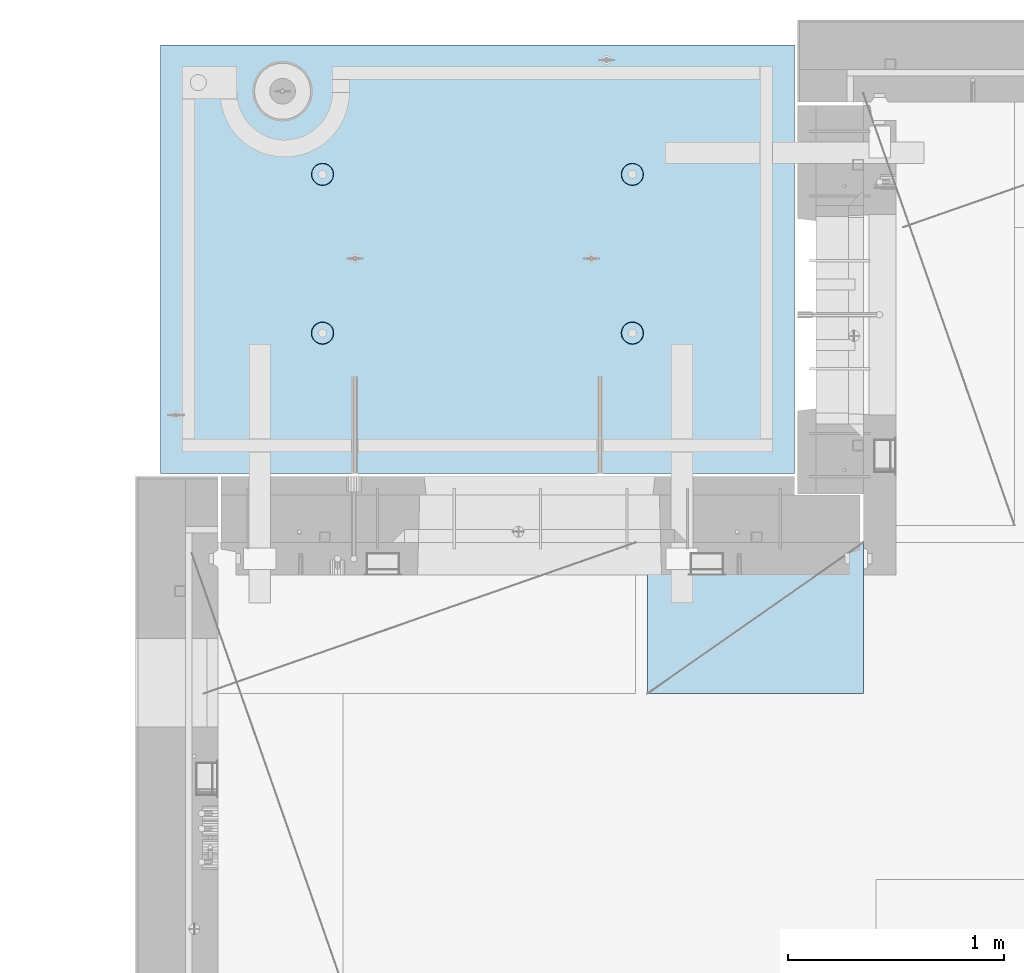
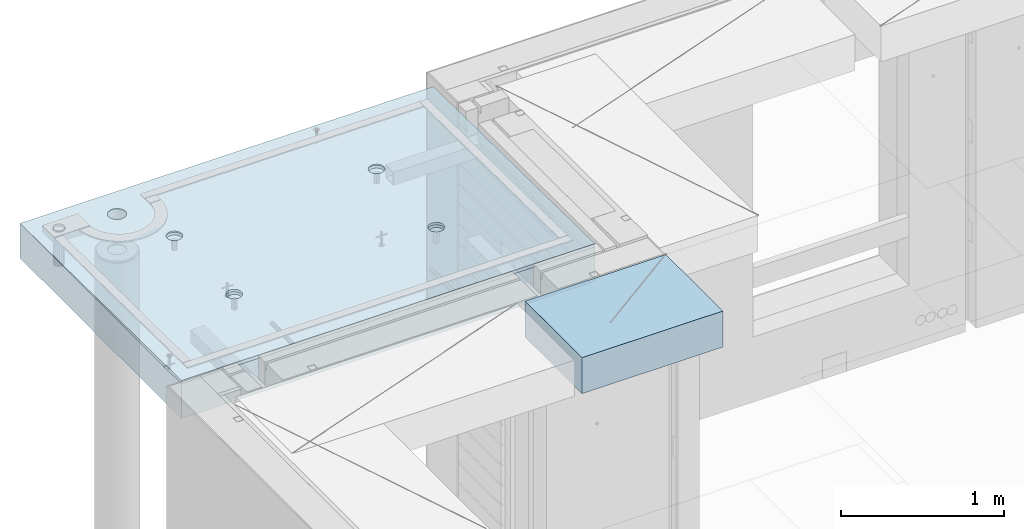
# One storey, part 199 of 341: 2 slabs, 1 plate, 2 elements without a shape of their own.
"""IFC2X3 building model written with IfcOpenShell, lengths in millimetres."""

import ifcopenshell
import ifcopenshell.guid

model = None  # the IFC model being written
_history = None  # IfcOwnerHistory: only IFC2X3 demands one
_inside = {}  # id of a spatial element -> (the spatial element, [elements in it])
_under = {}  # id of a project, library or spatial element -> (it, [spatial elements below it])
_declared = {}  # id of a project -> (the project, [libraries it declares])
_typed = {}  # id of a type object -> (the type object, [elements of that type])
_made_of = {}  # id of a material, layer set ... -> (it, [elements and type objects made of it])


def new_model(schema):
    """Start an empty IFC model of exactly this schema.

    Asked for "IFC4X3", IfcOpenShell would pick the latest addendum, in which some entities
    have other attributes; the version numbers below select the first issue.
    IFC2X3 requires an IfcOwnerHistory on every rooted entity: one is made here for all.
    """
    global model, _history
    if schema == "IFC4X3":
        model = ifcopenshell.file(schema_version=(4, 3, 0, 0))
    else:
        model = ifcopenshell.file(schema=schema)
    _inside.clear()
    _under.clear()
    _declared.clear()
    _typed.clear()
    _made_of.clear()
    _history = None
    if model.schema == "IFC2X3":
        org = make("IfcOrganization", Name="unknown")
        user = make(
            "IfcPersonAndOrganization",
            ThePerson=make("IfcPerson", FamilyName="unknown"),
            TheOrganization=org,
        )
        app = make(
            "IfcApplication",
            ApplicationDeveloper=org,
            Version="unknown",
            ApplicationFullName="unknown",
            ApplicationIdentifier="unknown",
        )
        _history = make(
            "IfcOwnerHistory",
            OwningUser=user,
            OwningApplication=app,
            ChangeAction="ADDED",
            CreationDate=0,
        )
    return model


def make(cls, **values):
    """One entity of the class cls with the attributes given. An attribute that is None is left unset."""
    return model.create_entity(
        cls, **{name: value for name, value in values.items() if value is not None}
    )


def rooted(cls, **values):
    """An entity with a GlobalId (a new one), such as an element, a storey or a relation."""
    return make(cls, GlobalId=ifcopenshell.guid.new(), OwnerHistory=_history, **values)


def si_unit(unit_type, name, prefix=None):
    """IfcSIUnit, for example si_unit("LENGTHUNIT", "METRE", prefix="MILLI")."""
    return make("IfcSIUnit", UnitType=unit_type, Prefix=prefix, Name=name)


def assignment(units):
    """IfcUnitAssignment: the units of a project."""
    return None if units is None else make("IfcUnitAssignment", Units=units)


def point(xyz):
    """IfcCartesianPoint."""
    return None if xyz is None else make("IfcCartesianPoint", Coordinates=xyz)


def direction(xyz):
    """IfcDirection."""
    return None if xyz is None else make("IfcDirection", DirectionRatios=xyz)


def frame(location, z_axis=None, x_axis=None):
    """IfcAxis2Placement3D, a coordinate frame: its origin and axes. An axis left out is left unset."""
    return make(
        "IfcAxis2Placement3D",
        Location=point(location),
        Axis=direction(z_axis),
        RefDirection=direction(x_axis),
    )


def origin_with_axes():
    """The frame at (0, 0, 0) with the z axis (0, 0, 1) and the x axis (1, 0, 0) written out."""
    return frame((0.0, 0.0, 0.0), z_axis=(0.0, 0.0, 1.0), x_axis=(1.0, 0.0, 0.0))


def place(relative_to, where):
    """IfcLocalPlacement: puts the frame where relative to a parent placement (None: the world)."""
    return make(
        "IfcLocalPlacement", PlacementRelTo=relative_to, RelativePlacement=where
    )


def context(
    kind, dimensions, precision=None, world=None, true_north=None, identifier=None
):
    """IfcGeometricRepresentationContext, for example the 3D "Model" context."""
    return make(
        "IfcGeometricRepresentationContext",
        ContextIdentifier=identifier,
        ContextType=kind,
        CoordinateSpaceDimension=dimensions,
        Precision=precision,
        WorldCoordinateSystem=world,
        TrueNorth=true_north,
    )


def subcontext(parent, identifier, kind, view, scale=None):
    """IfcGeometricRepresentationSubContext, for example "Body" below "Model"."""
    return make(
        "IfcGeometricRepresentationSubContext",
        ContextIdentifier=identifier,
        ContextType=kind,
        ParentContext=parent,
        TargetScale=scale,
        TargetView=view,
    )


def project(units=None, contexts=None):
    """IfcProject with its units and contexts."""
    return rooted(
        "IfcProject",
        Name="project",
        RepresentationContexts=contexts,
        UnitsInContext=assignment(units),
    )


def spatial(cls, under=None, at=None, **own):
    """A site, building, storey or space (cls), placed at a placement, below another one or the project."""
    s = rooted(cls, ObjectPlacement=at, **own)
    if under is not None:
        _under.setdefault(under.id(), (under, []))[1].append(s)
    return s


def faces_of(points, faces, orient=None, outer=None):
    """IfcFace entities. A face is a list of loops; a loop is a list of indices into points, from 0.

    orient and outer hold one flag for each loop. By default every Orientation is true, the
    first loop of a face is its IfcFaceOuterBound and the others are IfcFaceBound.
    """
    made = []
    for i, loops in enumerate(faces):
        bounds = []
        for j, loop in enumerate(loops):
            is_outer = j == 0 if outer is None else outer[i][j]
            bounds.append(
                make(
                    "IfcFaceOuterBound" if is_outer else "IfcFaceBound",
                    Bound=make("IfcPolyLoop", Polygon=[points[k] for k in loop]),
                    Orientation=True if orient is None else orient[i][j],
                )
            )
        made.append(make("IfcFace", Bounds=bounds))
    return made


def faceted_brep(points, faces, orient=None, outer=None, voids=None):
    """IfcFacetedBrep: a solid bounded by flat faces; with voids (closed shells), ...WithVoids."""
    shared = [point(p) for p in points]
    hull = make("IfcClosedShell", CfsFaces=faces_of(shared, faces, orient, outer))
    if voids is None:
        return make("IfcFacetedBrep", Outer=hull)
    return make(
        "IfcFacetedBrepWithVoids",
        Outer=hull,
        Voids=[
            make(cls, CfsFaces=faces_of(shared, fs, o, b)) for cls, fs, o, b in voids
        ],
    )


def shape(context_of_items, identifier, shape_type, items):
    """IfcShapeRepresentation: the items that make up one representation, for example the "Body"."""
    return make(
        "IfcShapeRepresentation",
        ContextOfItems=context_of_items,
        RepresentationIdentifier=identifier,
        RepresentationType=shape_type,
        Items=items,
    )


def material(Name=None, Category=None):
    """IfcMaterial."""
    return make("IfcMaterial", Name=Name, Category=Category)


def made_of(thing, what):
    """Note that an element or type object is made of a material, layer set ...; save() writes the relation."""
    if what is not None:
        _made_of.setdefault(what.id(), (what, []))[1].append(thing)
    return thing


def type_object(cls, material=None, **own):
    """A type object (cls), such as IfcWallType, which elements share."""
    return made_of(rooted(cls, **own), material)


def element(
    cls,
    number,
    at=None,
    inside=None,
    cuts=None,
    type_object=None,
    material=None,
    context=None,
    identifier="Body",
    shape_type=None,
    held_by="IfcProductDefinitionShape",
    body=None,
    shapes=None,
    **own,
):
    """One element of the class cls, such as IfcWall. Its Tag is "e" and its number.

    at: its placement. inside: the storey or other place that contains it. cuts: it is an
    opening in that element (IfcRelVoidsElement). A single representation is given by context,
    identifier, shape_type and body (its items); several are given by shapes. held_by: the class
    of the entity that holds the representations. save() writes the other relations.
    """
    e = rooted(cls, Tag="e%d" % number, ObjectPlacement=at, **own)
    if body is not None:
        shapes = [shape(context, identifier, shape_type, body)]
    if shapes is not None:
        e.Representation = make(held_by, Representations=shapes)
    if inside is not None:
        _inside.setdefault(inside.id(), (inside, []))[1].append(e)
    if cuts is not None:
        rooted(
            "IfcRelVoidsElement", RelatingBuildingElement=cuts, RelatedOpeningElement=e
        )
    if type_object is not None:
        _typed.setdefault(type_object.id(), (type_object, []))[1].append(e)
    return made_of(e, material)


def aggregate(whole, parts):
    """IfcRelAggregates: a whole, such as a stair, and the parts it consists of."""
    return rooted("IfcRelAggregates", RelatingObject=whole, RelatedObjects=parts)


def save(model, path):
    """Write the relations noted so far, then the file.

    IfcRelAggregates (storeys below a building ...), IfcRelContainedInSpatialStructure (elements
    in a storey), IfcRelDefinesByType, IfcRelAssociatesMaterial and IfcRelDeclares: one each for
    every whole, place, type object, material and project.
    """
    for whole, parts in _under.values():
        aggregate(whole, parts)
    for where, things in _inside.values():
        rooted(
            "IfcRelContainedInSpatialStructure",
            RelatedElements=things,
            RelatingStructure=where,
        )
    for kind, things in _typed.values():
        rooted("IfcRelDefinesByType", RelatedObjects=things, RelatingType=kind)
    for what, things in _made_of.values():
        rooted("IfcRelAssociatesMaterial", RelatedObjects=things, RelatingMaterial=what)
    for by, libraries in _declared.values():
        rooted("IfcRelDeclares", RelatingContext=by, RelatedDefinitions=libraries)
    model.write(path)


model = new_model("IFC2X3")

# Units and contexts
model_context = context("Model", 3, precision=1e-05, world=origin_with_axes())
body_context = subcontext(model_context, "Body", "Model", "MODEL_VIEW")
ifc_project = project(units=[si_unit("LENGTHUNIT", "METRE", prefix="MILLI"), si_unit("AREAUNIT", "SQUARE_METRE"), si_unit("VOLUMEUNIT", "CUBIC_METRE"), si_unit("MASSUNIT", "GRAM", prefix="KILO"), si_unit("TIMEUNIT", "SECOND"), si_unit("PLANEANGLEUNIT", "RADIAN"), si_unit("SOLIDANGLEUNIT", "STERADIAN"), si_unit("THERMODYNAMICTEMPERATUREUNIT", "DEGREE_CELSIUS"), si_unit("LUMINOUSINTENSITYUNIT", "LUMEN")], contexts=[model_context])

# Site, building, storey
site_placement = place(None, origin_with_axes())
site = spatial("IfcSite", under=ifc_project, at=site_placement, CompositionType="ELEMENT")
building_placement = place(site_placement, origin_with_axes())
building = spatial("IfcBuilding", under=site, at=building_placement, CompositionType="ELEMENT")
storey_placement = place(building_placement, origin_with_axes())
storey = spatial("IfcBuildingStorey", under=building, at=storey_placement, Name="5", CompositionType="ELEMENT", Elevation=0.0)

# Assembly, slabs
assembly_1_placement = place(storey_placement, origin_with_axes())
assembly_1 = element("IfcElementAssembly", 1, at=assembly_1_placement, inside=storey, AssemblyPlace="NOTDEFINED", PredefinedType="REINFORCEMENT_UNIT")
ifc_material_1 = material(Name="CONCRETE/C35/45")
slab_type_1 = type_object("IfcSlabType", PredefinedType="NOTDEFINED")
slab_1_placement = place(assembly_1_placement, frame((7734.99985681325, 20899.9965573523, 96717.5), z_axis=(0.0, 1.0, 0.0), x_axis=(1.0, 0.0, 0.0)))
slab_1 = element("IfcSlab", 2, at=slab_1_placement, type_object=slab_type_1, material=ifc_material_1, PredefinedType="FLOOR", context=body_context, shape_type="Brep", body=[
    faceted_brep([(209.64691778923, 8.87688398158934, 1795.66138892724), (209.64691778923, 12.5000000975269, 1795.66138892724), (201.519156607756, 12.5000000956934, 1783.49470026561), (201.519156607756, 8.73204270274437, 1783.49470026561), (189.354094229504, 12.5000000940054, 1775.36450517907), (189.354094229504, 8.63525483493868, 1775.36450517907), (175.003751124998, 12.5000000927103, 1772.50855216914), (175.003751124998, 8.60125545370101, 1772.50855216914), (160.652836945715, 12.5000000920118, 1775.36163419229), (160.652836945715, 8.63522065659345, 1775.36163419229), (148.48614828409, 12.5000000919972, 1783.48939537376), (148.48614828409, 8.73197954936768, 1783.48939537376), (140.355953197546, 12.5000000926811, 1795.65445775201), (140.355953197546, 8.87680146773346, 1795.65445775201), (137.500000187611, 12.5000000939617, 1810.00480085652), (137.500000187611, 9.04763858744991, 1810.00480085652), (140.353082210766, 12.5000000956497, 1824.35571503581), (140.353082210766, 9.21848250564653, 1824.35571503581), (148.48084339224, 12.5000000974687, 1836.52240369743), (148.48084339224, 9.36332378449151, 1836.52240369743), (160.645905770492, 12.5000000991568, 1844.65259878397), (160.645905770492, 9.4601116522972, 1844.65259878397), (174.996248874998, 12.5000001004519, 1847.50855179391), (174.996248874998, 9.49411103353486, 1847.50855179391), (189.347163054282, 12.5000001011649, 1844.65546977075), (189.347163054282, 9.46014583064243, 1844.65546977075), (201.513851715907, 12.5000001011795, 1836.52770858928), (201.513851715907, 9.3633869378682, 1836.52770858928), (209.64404680245, 12.500000100481, 1824.36264621103), (209.64404680245, 9.21856501948787, 1824.36264621103), (212.499999812386, 12.5000000992004, 1810.01230310652), (212.499999812386, 9.04772789980052, 1810.01230310652), (0.0, 12.5, 1985.00366210938), (7.41420080885291e-08, 12.4999999999927, 0.0), (-7.41420080885291e-08, -12.5, -3.63797880709171e-12), (0.0, 11.1309547276614, 1985.00366210938), (2935.0, 12.5000004097383, 1985.00366209901), (2935.0, 11.1309547276614, 1985.00366210938), (2935.0, 12.5, 0.0), (2935.0, -12.5, 0.0), (2234.65136896188, -4.56985165992228, 666.133623356985), (2233.6850359994, 12.5000001221924, 665.819642744358), (2236.1904762364, 12.5000001207372, 650.000915653603), (2237.21797072983, -4.76190736876742, 650.000915653603), (2227.22763735012, -4.39666783543362, 680.68109000706), (2226.41396523543, 12.5000001231529, 680.089922611885), (2215.67536748502, -4.25927704213245, 692.221936790684), (2215.08900701139, 12.5000001235312, 691.414880835895), (2201.12537297611, -4.17108941465267, 699.629710429519), (2200.81872714385, 12.5000001232838, 698.685951599829), (2185.00000005312, -4.14070613867079, 702.181910066618), (2185.00000005312, 12.5000001224398, 701.19139183679), (2168.87462713012, -4.17108941465267, 699.629710429519), (2169.18127296234, 12.5000001210865, 698.685951599953), (2154.32463262121, -4.25927704213245, 692.221936790684), (2154.9109930947, 12.5000001193257, 691.414880836099), (2142.77236275611, -4.39666783543362, 680.68109000706), (2143.58603487053, 12.5000001173757, 680.089922612086), (2135.34863114435, -4.56985165992228, 666.133623356985), (2136.31496410644, 12.5000001153967, 665.819642744485), (2132.7820293764, -4.76190736876742, 650.000915653603), (2133.8095238694, 12.5000001135923, 650.000915653603), (2135.3268816397, -4.95404720651277, 633.861141107776), (2136.31496410626, 12.5000001121371, 634.182188562663), (2142.73717131393, -5.12745128343522, 619.29517322078), (2143.58603487023, 12.5000001111621, 619.911908694903), (2154.28944117357, -5.26511432380357, 607.731457644233), (2154.9109930944, 12.5000001107837, 608.586950470697), (2168.85287761663, -5.35352220384812, 600.305182758089), (2169.18127296215, 12.5000001110311, 601.315879706683), (2185.00000005312, -5.38398960883205, 597.745916272124), (2185.00000005312, 12.5000001118751, 598.810439469788), (2201.1471224896, -5.35352220384812, 600.305182758089), (2200.81872714404, 12.500000113243, 601.31587970681), (2215.71055893266, -5.26511432380357, 607.731457644233), (2215.08900701168, 12.5000001149892, 608.586950470901), (2227.2628287923, -5.12745128343522, 619.29517322078), (2226.41396523573, 12.5000001169392, 619.911908695103), (2234.67311846653, -4.95404720651277, 633.861141107776), (2233.68503599959, 12.5000001189328, 634.182188562787), (799.651368961879, -4.56985165992228, 666.133623356985), (798.685036005074, 12.5000000220316, 665.819642746203), (801.190476242367, 12.5000000205619, 650.000915653603), (802.217970729829, -4.76190736876742, 650.000915653603), (792.227637350119, -4.39666783543362, 680.68109000706), (791.41396524025, 12.500000022992, 680.089922615389), (780.675367485019, -4.25927704213245, 692.221936790684), (780.089007014889, 12.5000000233704, 691.414880840719), (766.125372976112, -4.17108941465267, 699.629710429519), (765.818727145695, 12.500000023123, 698.685951605497), (750.000000053116, -4.14070613867079, 702.181910066618), (750.000000053116, 12.500000022279, 701.191391842753), (733.874627130121, -4.17108941465267, 699.629710429519), (734.181272960497, 12.5000000209257, 698.685951605625), (719.324632621214, -4.25927704213245, 692.221936790684), (719.910993091196, 12.5000000191649, 691.414880840923), (707.772362756114, -4.39666783543362, 680.68109000706), (708.586034865702, 12.5000000172149, 680.089922615593), (700.348631144354, -4.56985165992228, 666.133623356985), (701.314964100775, 12.5000000152359, 665.819642746326), (697.782029376403, -4.76190736876742, 650.000915653603), (698.80952386344, 12.5000000134314, 650.000915653603), (700.326881639705, -4.95404720651277, 633.861141107776), (701.314964100589, 12.5000000119617, 634.182188560822), (707.737171313933, -5.12745128343522, 619.29517322078), (708.586034865404, 12.5000000110012, 619.911908691396), (719.289441173572, -5.26511432380357, 607.731457644233), (719.910993090896, 12.5000000106229, 608.586950465873), (733.852877616633, -5.35352220384812, 600.305182758089), (734.181272960313, 12.5000000108703, 601.315879701015), (750.000000053116, -5.38398960883205, 597.745916272124), (750.000000053116, 12.5000000117143, 598.810439463825), (766.1471224896, -5.35352220384812, 600.305182758089), (765.818727145879, 12.5000000130822, 601.315879701138), (780.71055893266, -5.26511432380357, 607.731457644233), (780.089007015189, 12.5000000148284, 608.586950466077), (792.2628287923, -5.12745128343522, 619.29517322078), (791.413965240548, 12.5000000167784, 619.9119086916), (799.673118466528, -4.95404720651277, 633.861141107776), (798.685036005258, 12.500000018772, 634.182188560946), (799.156135017123, 4.17823925742414, 1400.9745431382), (798.685035917459, 12.5000000978907, 1400.82147376184), (801.190476154532, 12.5000000964355, 1385.00274667064), (801.697136924844, 3.98809915517631, 1385.00274667064), (791.806449365287, 4.3496957076859, 1415.37691010137), (791.413965153277, 12.5000000988512, 1415.09175362977), (780.369404424282, 4.48571613449894, 1426.80264589727), (780.089006928914, 12.5000000992295, 1426.4167118541), (765.96453481571, 4.57302415884624, 1434.13653274457), (765.818727060978, 12.5000000989821, 1433.68778261824), (749.999999969796, 4.6031043852272, 1436.66327617152), (749.999999969796, 12.5000000981381, 1436.19322285528), (734.035465123881, 4.57302415884624, 1434.13653274457), (734.181272878572, 12.5000000967848, 1433.68778261837), (719.630595515309, 4.48571613449894, 1426.80264589727), (719.91099301053, 12.5000000950386, 1426.41671185431), (708.193550574304, 4.3496957076859, 1415.37691010137), (708.586034786036, 12.5000000930741, 1415.09175362997), (700.843864922468, 4.17823925742414, 1400.9745431382), (701.314964021747, 12.500000091095, 1400.82147376197), (698.302863014747, 3.98809915517631, 1385.00274667064), (698.809523784634, 12.500000089276, 1385.00274667064), (700.822332352242, 3.79787576314993, 1369.0239538469), (701.314964021563, 12.5000000878208, 1369.18401957925), (708.15871013944, 3.62620125728427, 1354.60327018229), (708.586034785736, 12.5000000868604, 1354.91373971109), (719.595755075041, 3.48991129887872, 1343.15489369192), (719.91099301023, 12.500000086482, 1343.58878148656), (734.013932544907, 3.40238521881111, 1335.80269013289), (734.181272878388, 12.5000000867294, 1336.31771072235), (749.999999969796, 3.37222170254972, 1333.26895034341), (749.999999969796, 12.5000000875589, 1333.81227048538), (765.986067394684, 3.40238521881111, 1335.80269013289), (765.818727061163, 12.5000000889413, 1336.31771072247), (780.40424486455, 3.48991129887872, 1343.15489369192), (780.089006929215, 12.500000090673, 1343.58878148677), (791.841289800152, 3.62620125728427, 1354.60327018229), (791.413965153577, 12.5000000926375, 1354.91373971129), (799.17766758735, 3.79787576314993, 1369.0239538469), (798.685035917644, 12.5000000946166, 1369.18401957938), (2234.15613501712, 4.17823925742414, 1400.9745431382), (2233.68503591179, 12.5000001980516, 1400.82147376), (2236.19047614857, 12.5000001965964, 1385.00274667064), (2236.69713692484, 3.98809915517631, 1385.00274667064), (2226.80644936529, 4.3496957076859, 1415.37691010137), (2226.41396514845, 12.5000001990265, 1415.09175362627), (2215.36940442428, 4.48571613449894, 1426.80264589727), (2215.08900692541, 12.5000001993903, 1426.41671184928), (2200.96453481571, 4.57302415884624, 1434.13653274457), (2200.81872705914, 12.5000001991575, 1433.68778261257), (2184.9999999698, 4.6031043852272, 1436.66327617152), (2184.9999999698, 12.5000001982989, 1436.19322284931), (2169.03546512388, 4.57302415884624, 1434.13653274457), (2169.18127288041, 12.5000001969456, 1433.6877826127), (2154.63059551531, 4.48571613449894, 1426.80264589727), (2154.91099301403, 12.5000001951994, 1426.41671184948), (2143.1935505743, 4.3496957076859, 1415.37691010137), (2143.58603479086, 12.5000001932349, 1415.09175362647), (2135.84386492247, 4.17823925742414, 1400.9745431382), (2136.31496402742, 12.5000001912558, 1400.82147376013), (2133.30286301475, 3.98809915517631, 1385.00274667064), (2133.8095237906, 12.5000001894368, 1385.00274667064), (2135.82233235224, 3.79787576314993, 1369.0239538469), (2136.31496402723, 12.5000001879816, 1369.18401958109), (2143.15871013944, 3.62620125728427, 1354.60327018229), (2143.58603479056, 12.5000001870212, 1354.91373971459), (2154.59575507504, 3.48991129887872, 1343.15489369192), (2154.91099301373, 12.5000001866429, 1343.58878149139), (2169.01393254491, 3.40238521881111, 1335.80269013289), (2169.18127288023, 12.5000001868902, 1336.31771072802), (2184.9999999698, 3.37222170254972, 1333.26895034341), (2184.9999999698, 12.5000001877343, 1333.81227049134), (2200.98606739468, 3.40238521881111, 1335.80269013289), (2200.81872705932, 12.5000001891021, 1336.31771072814), (2215.40424486455, 3.48991129887872, 1343.15489369192), (2215.08900692571, 12.5000001908338, 1343.58878149159), (2226.84128980015, 3.62620125728427, 1354.60327018229), (2226.41396514875, 12.5000001927983, 1354.9137397148), (2234.17766758735, 3.79787576314993, 1369.0239538469), (2233.68503591197, 12.5000001947919, 1369.18401958122), (613.539958053605, 8.15176414522284, 1734.75121634823), (600.266053528658, 7.99374174815603, 1721.47731182328), (583.539958053605, 7.89228512388945, 1712.95494050807), (564.998938391109, 7.85732555369032, 1710.01833148578), (546.457918728613, 7.89228512388945, 1712.95494050807), (529.73182325356, 7.99374174815603, 1721.47731182328), (516.457918728613, 8.15176414522284, 1734.75121634823), (507.935547413399, 8.35088398186781, 1751.47731182328), (504.998938391109, 8.57161002114299, 1770.01833148578), (507.935547413399, 8.79233606038906, 1788.55935114828), (516.457918728613, 8.99145589703403, 1805.28544662333), (529.73182325356, 9.1494782941154, 1818.55935114828), (546.457918728613, 9.25093491838197, 1827.08172246349), (564.998938391109, 9.28589448856656, 1830.01833148578), (583.539958053605, 9.25093491838197, 1827.08172246349), (600.266053528658, 9.1494782941154, 1818.55935114828), (613.539958053605, 8.99145589703403, 1805.28544662333), (622.062329368819, 8.79233606038906, 1788.55935114828), (624.998938391109, 8.57161002114299, 1770.01833148578), (622.062329368819, 8.35088398186781, 1751.47731182328), (613.539958053605, 12.5, 1805.28544662333), (622.062329368819, 12.5, 1788.55935114828), (600.266053528658, 12.5, 1818.55935114828), (583.539958053605, 12.5, 1827.08172246349), (564.998938391109, 12.5, 1830.01833148578), (546.457918728613, 12.5, 1827.08172246349), (529.73182325356, 12.5, 1818.55935114828), (516.457918728613, 12.5, 1805.28544662333), (507.935547413399, 12.5, 1788.55935114828), (504.998938391109, 12.5, 1770.01833148578), (507.935547413399, 12.5, 1751.47731182328), (516.457918728613, 12.5, 1734.75121634823), (529.73182325356, 12.5, 1721.47731182328), (546.457918728613, 12.5, 1712.95494050807), (564.998938391109, 12.5, 1710.01833148578), (583.539958053605, 12.5, 1712.95494050807), (600.266053528658, 12.5, 1721.47731182328), (613.539958053605, 12.5, 1734.75121634823), (622.062329368819, 12.5, 1751.47731182328), (624.998938391109, 12.5, 1770.01833148578)], [[[0, 1, 2, 3]], [[3, 2, 4, 5]], [[5, 4, 6, 7]], [[7, 6, 8, 9]], [[9, 8, 10, 11]], [[11, 10, 12, 13]], [[13, 12, 14, 15]], [[15, 14, 16, 17]], [[17, 16, 18, 19]], [[19, 18, 20, 21]], [[21, 20, 22, 23]], [[23, 22, 24, 25]], [[25, 24, 26, 27]], [[27, 26, 28, 29]], [[29, 28, 30, 31]], [[31, 30, 1, 0]], [[32, 33, 34, 35]], [[36, 32, 35, 37]], [[38, 36, 37, 39]], [[33, 38, 39, 34]], [[40, 41, 42, 43]], [[44, 45, 41, 40]], [[46, 47, 45, 44]], [[48, 49, 47, 46]], [[50, 51, 49, 48]], [[52, 53, 51, 50]], [[53, 52, 54, 55]], [[55, 54, 56, 57]], [[57, 56, 58, 59]], [[59, 58, 60, 61]], [[61, 60, 62, 63]], [[63, 62, 64, 65]], [[65, 64, 66, 67]], [[67, 66, 68, 69]], [[69, 68, 70, 71]], [[72, 73, 71, 70]], [[74, 75, 73, 72]], [[76, 77, 75, 74]], [[78, 79, 77, 76]], [[43, 42, 79, 78]], [[80, 81, 82, 83]], [[84, 85, 81, 80]], [[86, 87, 85, 84]], [[88, 89, 87, 86]], [[90, 91, 89, 88]], [[92, 93, 91, 90]], [[93, 92, 94, 95]], [[95, 94, 96, 97]], [[97, 96, 98, 99]], [[99, 98, 100, 101]], [[101, 100, 102, 103]], [[103, 102, 104, 105]], [[105, 104, 106, 107]], [[107, 106, 108, 109]], [[109, 108, 110, 111]], [[112, 113, 111, 110]], [[114, 115, 113, 112]], [[116, 117, 115, 114]], [[118, 119, 117, 116]], [[83, 82, 119, 118]], [[120, 121, 122, 123]], [[124, 125, 121, 120]], [[126, 127, 125, 124]], [[128, 129, 127, 126]], [[130, 131, 129, 128]], [[132, 133, 131, 130]], [[134, 135, 133, 132]], [[135, 134, 136, 137]], [[137, 136, 138, 139]], [[139, 138, 140, 141]], [[141, 140, 142, 143]], [[143, 142, 144, 145]], [[145, 144, 146, 147]], [[147, 146, 148, 149]], [[149, 148, 150, 151]], [[151, 150, 152, 153]], [[154, 155, 153, 152]], [[156, 157, 155, 154]], [[158, 159, 157, 156]], [[123, 122, 159, 158]], [[160, 161, 162, 163]], [[164, 165, 161, 160]], [[166, 167, 165, 164]], [[168, 169, 167, 166]], [[170, 171, 169, 168]], [[172, 173, 171, 170]], [[174, 175, 173, 172]], [[175, 174, 176, 177]], [[177, 176, 178, 179]], [[179, 178, 180, 181]], [[181, 180, 182, 183]], [[183, 182, 184, 185]], [[185, 184, 186, 187]], [[187, 186, 188, 189]], [[189, 188, 190, 191]], [[191, 190, 192, 193]], [[194, 195, 193, 192]], [[196, 197, 195, 194]], [[198, 199, 197, 196]], [[163, 162, 199, 198]], [[37, 35, 34, 39], [3, 5, 7, 9, 11, 13, 15, 17, 19, 21, 23, 25, 27, 29, 31, 0], [200, 201, 202, 203, 204, 205, 206, 207, 208, 209, 210, 211, 212, 213, 214, 215, 216, 217, 218, 219], [196, 194, 192, 190, 188, 186, 184, 182, 180, 178, 176, 174, 172, 170, 168, 166, 164, 160, 163, 198], [156, 154, 152, 150, 148, 146, 144, 142, 140, 138, 136, 134, 132, 130, 128, 126, 124, 120, 123, 158], [116, 114, 112, 110, 108, 106, 104, 102, 100, 98, 96, 94, 92, 90, 88, 86, 84, 80, 83, 118], [76, 74, 72, 70, 68, 66, 64, 62, 60, 58, 56, 54, 52, 50, 48, 46, 44, 40, 43, 78]], [[216, 220, 221, 217]], [[215, 222, 220, 216]], [[214, 223, 222, 215]], [[213, 224, 223, 214]], [[212, 225, 224, 213]], [[211, 226, 225, 212]], [[210, 227, 226, 211]], [[209, 228, 227, 210]], [[208, 229, 228, 209]], [[207, 230, 229, 208]], [[206, 231, 230, 207]], [[205, 232, 231, 206]], [[204, 233, 232, 205]], [[203, 234, 233, 204]], [[202, 235, 234, 203]], [[201, 236, 235, 202]], [[200, 237, 236, 201]], [[219, 238, 237, 200]], [[218, 239, 238, 219]], [[217, 221, 239, 218]], [[38, 33, 32, 36], [26, 24, 22, 20, 18, 16, 14, 12, 10, 8, 6, 4, 2, 1, 30, 28], [220, 222, 223, 224, 225, 226, 227, 228, 229, 230, 231, 232, 233, 234, 235, 236, 237, 238, 239, 221], [165, 167, 169, 171, 173, 175, 177, 179, 181, 183, 185, 187, 189, 191, 193, 195, 197, 199, 162, 161], [125, 127, 129, 131, 133, 135, 137, 139, 141, 143, 145, 147, 149, 151, 153, 155, 157, 159, 122, 121], [85, 87, 89, 91, 93, 95, 97, 99, 101, 103, 105, 107, 109, 111, 113, 115, 117, 119, 82, 81], [45, 47, 49, 51, 53, 55, 57, 59, 61, 63, 65, 67, 69, 71, 73, 75, 77, 79, 42, 41]]]),
])
slab_type_2 = type_object("IfcSlabType", PredefinedType="NOTDEFINED")
slab_2_placement = place(assembly_1_placement, frame((7734.99985681325, 20899.9965573523, 96575.0), z_axis=(-2.2639999995273e-06, 0.999999999997437, 0.0), x_axis=(0.999999999997251, 2.34499999952812e-06, 0.0)))
slab_2 = element("IfcSlab", 3, at=slab_2_placement, type_object=slab_type_2, material=ifc_material_1, PredefinedType="FLOOR", context=body_context, shape_type="Brep", body=[
    faceted_brep([(2200.45398600256, -110.0, 1337.44476079497), (2214.39241555253, -110.0, 1344.54670420538), (2225.45402859605, -110.0, 1355.60826537005), (2232.55603737762, -110.0, 1369.54666161175), (2235.0032477951, -110.0, 1384.99750559184), (2232.5561098421, -110.0, 1400.44836104917), (2225.45416643169, -110.0, 1414.38679059914), (2214.39260526702, -110.0, 1425.44840364265), (2200.45420902531, -110.0, 1432.55041242422), (2185.00336504523, -110.0, 1434.9976228417), (2169.55250958791, -110.0, 1432.55048488871), (2155.61408003793, -110.0, 1425.44854147829), (2144.55246699442, -110.0, 1414.38698031362), (2137.45045821285, -110.0, 1400.44858407192), (2135.00324779537, -110.0, 1384.99774009184), (2137.45038574836, -110.0, 1369.54688463451), (2144.55232915878, -110.0, 1355.60845508454), (2155.61389032345, -110.0, 1344.54684204102), (2169.55228656515, -110.0, 1337.44483325945), (2185.00313054523, -110.0, 1334.99762284198), (2226.41728354208, -130.0, 1415.08653268859), (2233.68832084322, -130.0, 1400.81623576839), (2215.09235187349, -130.0, 1426.41151747124), (2200.8220890546, -130.0, 1433.68262169999), (2185.0033678369, -130.0, 1436.18809903217), (2169.18463486868, -130.0, 1433.68269588982), (2154.91433794847, -130.0, 1426.41165858869), (2143.58935316583, -130.0, 1415.08672692009), (2136.31824893708, -130.0, 1400.81646410121), (2133.8127716049, -130.0, 1384.9977428835), (2136.31817474725, -130.0, 1369.17900991529), (2143.58921204838, -130.0, 1354.90871299508), (2154.91414371698, -130.0, 1343.58372821243), (2169.18440653586, -130.0, 1336.31262398369), (2185.00312775357, -130.0, 1333.8071466515), (2200.82186072178, -130.0, 1336.31254979386), (2215.09215764199, -130.0, 1343.58358709499), (2226.41714242464, -130.0, 1354.90851876358), (2233.68824665339, -130.0, 1369.17878158247), (2236.19372398557, -130.0, 1384.99750280017), (765.453986006505, -110.0, 1337.44812586997), (779.392415556478, -110.0, 1344.55006928038), (790.454028599992, -110.0, 1355.61163044505), (797.556037381562, -110.0, 1369.55002668675), (800.003247799041, -110.0, 1385.00087066684), (797.556109846048, -110.0, 1400.45172612417), (790.454166435635, -110.0, 1414.39015567414), (779.392605270965, -110.0, 1425.45176871765), (765.45420902926, -110.0, 1432.55377749922), (750.003365049179, -110.0, 1435.0009879167), (734.552509591851, -110.0, 1432.55384996371), (720.614080041878, -110.0, 1425.4519065533), (709.552466998364, -110.0, 1414.39034538862), (702.450458216794, -110.0, 1400.45194914692), (700.003247799315, -110.0, 1385.00110516684), (702.450385752309, -110.0, 1369.5502497095), (709.552329162721, -110.0, 1355.61182015954), (720.613890327391, -110.0, 1344.55020711602), (734.552286569096, -110.0, 1337.44819833446), (750.003130549179, -110.0, 1335.00098791698), (798.688320847163, -130.0, 1400.81960084339), (801.193723989514, -130.0, 1385.00086787517), (791.417283546027, -130.0, 1415.0898977636), (780.092351877434, -130.0, 1426.41488254624), (765.822089058547, -130.0, 1433.68598677499), (750.003367840845, -130.0, 1436.19146410717), (734.184634872629, -130.0, 1433.68606096482), (719.914337952418, -130.0, 1426.41502366369), (708.589353169771, -130.0, 1415.09009199509), (701.318248941023, -130.0, 1400.81982917621), (698.812771608842, -130.0, 1385.00110795851), (701.318174751194, -130.0, 1369.18237499029), (708.589212052329, -130.0, 1354.91207807008), (719.914143720922, -130.0, 1343.58709328743), (734.184406539811, -130.0, 1336.31598905868), (750.003127757513, -130.0, 1333.8105117265), (765.821860725729, -130.0, 1336.31591486885), (780.092157645939, -130.0, 1343.58695216999), (791.417142428585, -130.0, 1354.91188383858), (798.688246657333, -130.0, 1369.18214665747), (2935.0, -130.0, 1.16051523946226e-09), (0.0, -130.0, -3.63797880709171e-12), (0.0, 130.0, -1.81898940354586e-12), (2935.0, 130.0, 1.16051523946226e-09), (2935.00146484375, -130.0, 1985.00366210938), (2935.00146484375, 130.0, 1985.00366210938), (0.00127768016045593, -130.0, 1985.00366210937), (0.00127768016045593, 130.0, 1985.00366210937), (613.544191446293, 130.0, 1805.28400786653), (600.270318048689, 130.0, 1818.55794351875), (583.544242558642, 130.0, 1827.08035405663), (565.003229782545, 130.0, 1830.0170065576), (546.462203233751, 130.0, 1827.08044101401), (529.736087773786, 130.0, 1818.55810892152), (516.462152121568, 130.0, 1805.28423552391), (507.939741583684, 130.0, 1788.55816003387), (505.00308908271, 130.0, 1770.01714725777), (507.939654626302, 130.0, 1751.47612070897), (516.461986718798, 130.0, 1734.75000524901), (529.735860116402, 130.0, 1721.47606959679), (546.461935606448, 130.0, 1712.95365905891), (565.002948382545, 130.0, 1710.01700655793), (583.543974931338, 130.0, 1712.95357210152), (600.270090391306, 130.0, 1721.47590419402), (613.544026043523, 130.0, 1734.74977759163), (622.066436581407, 130.0, 1751.47585308167), (625.003089082381, 130.0, 1770.01686585777), (622.066523538789, 130.0, 1788.55789240656), (622.066523538789, -130.0, 1788.55789240656), (625.003089082381, -130.0, 1770.01686585777), (613.544191446293, -130.0, 1805.28400786653), (600.270318048689, -130.0, 1818.55794351875), (583.544242558642, -130.0, 1827.08035405663), (565.003229782545, -130.0, 1830.0170065576), (546.462203233751, -130.0, 1827.08044101401), (529.736087773786, -130.0, 1818.55810892152), (516.462152121568, -130.0, 1805.28423552391), (507.939741583684, -130.0, 1788.55816003387), (505.00308908271, -130.0, 1770.01714725777), (507.939654626302, -130.0, 1751.47612070897), (516.461986718798, -130.0, 1734.75000524901), (529.735860116402, -130.0, 1721.47606959679), (546.461935606448, -130.0, 1712.95365905891), (565.002948382545, -130.0, 1710.01700655793), (583.543974931338, -130.0, 1712.95357210152), (600.270090391306, -130.0, 1721.47590419402), (613.544026043523, -130.0, 1734.74977759163), (622.066436581407, -130.0, 1751.47585308167), (765.452262510529, -110.0, 602.446294854952), (779.390692060502, -110.0, 609.548238265361), (790.452305104016, -110.0, 620.609799430033), (797.554313885586, -110.0, 634.548195671738), (800.001524303065, -110.0, 649.999039651819), (797.554386350072, -110.0, 665.449895109152), (790.452442939657, -110.0, 679.388324659118), (779.390881774987, -110.0, 690.449937702637), (765.452485533282, -110.0, 697.551946484204), (750.001641553203, -110.0, 699.999156901682), (734.550786095873, -110.0, 697.552018948689), (720.6123565459, -110.0, 690.45007553828), (709.550743502386, -110.0, 679.388514373604), (702.448734720818, -110.0, 665.450118131903), (700.001524303339, -110.0, 649.999274151818), (702.448662256333, -110.0, 634.548418694489), (709.550605666745, -110.0, 620.609989144519), (720.612166831415, -110.0, 609.548376101004), (734.55056307312, -110.0, 602.446367319437), (750.001407053202, -110.0, 599.999156901958), (798.686597351187, -130.0, 665.817769828369), (801.192000493538, -130.0, 649.999036860154), (791.415560050051, -130.0, 680.088066748576), (780.090628381458, -130.0, 691.413051531228), (765.820365562571, -130.0, 698.684155759973), (750.001644344869, -130.0, 701.189633092159), (734.182911376653, -130.0, 698.684229949802), (719.912614456442, -130.0, 691.41319264867), (708.587629673795, -130.0, 680.088260980072), (701.316525445047, -130.0, 665.817998161187), (698.811048112866, -130.0, 649.999276943487), (701.316451255216, -130.0, 634.180543975268), (708.587488556352, -130.0, 619.910247055061), (719.912420224944, -130.0, 608.585262272412), (734.182683043833, -130.0, 601.314158043664), (750.001404261535, -130.0, 598.808680711485), (765.820137229752, -130.0, 601.314083853835), (780.090434149961, -130.0, 608.585121154971), (791.415418932607, -130.0, 619.910052823565), (798.686523161356, -130.0, 634.18031564245), (2200.45226250658, -110.0, 602.442929779951), (2214.39069205656, -110.0, 609.544873190363), (2225.45230510007, -110.0, 620.606434355035), (2232.55431388164, -110.0, 634.544830596737), (2235.00152429912, -110.0, 649.995674576818), (2232.55438634613, -110.0, 665.446530034151), (2225.45244293571, -110.0, 679.38495958412), (2214.39088177104, -110.0, 690.446572627639), (2200.45248552934, -110.0, 697.548581409203), (2185.00164154926, -110.0, 699.995791826681), (2169.55078609193, -110.0, 697.548653873688), (2155.61235654195, -110.0, 690.446710463279), (2144.55074349844, -110.0, 679.385149298603), (2137.44873471687, -110.0, 665.446753056905), (2135.00152429939, -110.0, 649.995909076821), (2137.44866225239, -110.0, 634.545053619491), (2144.5506056628, -110.0, 620.606624069518), (2155.61216682747, -110.0, 609.545011026003), (2169.55056306918, -110.0, 602.443002244436), (2185.00140704926, -110.0, 599.995791826957), (2233.68659734724, -130.0, 665.814404753368), (2236.19200048959, -130.0, 649.995671785153), (2226.41556004611, -130.0, 680.084701673575), (2215.09062837751, -130.0, 691.409686456227), (2200.82036555863, -130.0, 698.680790684972), (2185.00164434092, -130.0, 701.186268017158), (2169.18291137271, -130.0, 698.680864874805), (2154.9126144525, -130.0, 691.409827573672), (2143.58762966985, -130.0, 680.084895905075), (2136.3165254411, -130.0, 665.814633086189), (2133.81104810892, -130.0, 649.995911868486), (2136.31645125127, -130.0, 634.177178900271), (2143.58748855241, -130.0, 619.906881980063), (2154.912420221, -130.0, 608.581897197415), (2169.18268303989, -130.0, 601.310792968667), (2185.00140425759, -130.0, 598.805315636484), (2200.82013722581, -130.0, 601.310718778834), (2215.09043414602, -130.0, 608.58175607997), (2226.41541892866, -130.0, 619.906687748564), (2233.68652315741, -130.0, 634.176950567449)], [[[0, 1, 2, 3, 4, 5, 6, 7, 8, 9, 10, 11, 12, 13, 14, 15, 16, 17, 18, 19]], [[20, 6, 5, 21]], [[22, 7, 6, 20]], [[23, 8, 7, 22]], [[24, 9, 8, 23]], [[25, 10, 9, 24]], [[26, 11, 10, 25]], [[27, 12, 11, 26]], [[28, 13, 12, 27]], [[29, 14, 13, 28]], [[30, 15, 14, 29]], [[31, 16, 15, 30]], [[32, 17, 16, 31]], [[33, 18, 17, 32]], [[34, 19, 18, 33]], [[35, 0, 19, 34]], [[36, 1, 0, 35]], [[37, 2, 1, 36]], [[38, 3, 2, 37]], [[39, 4, 3, 38]], [[21, 5, 4, 39]], [[40, 41, 42, 43, 44, 45, 46, 47, 48, 49, 50, 51, 52, 53, 54, 55, 56, 57, 58, 59]], [[60, 45, 44, 61]], [[62, 46, 45, 60]], [[63, 47, 46, 62]], [[64, 48, 47, 63]], [[65, 49, 48, 64]], [[66, 50, 49, 65]], [[67, 51, 50, 66]], [[68, 52, 51, 67]], [[69, 53, 52, 68]], [[70, 54, 53, 69]], [[71, 55, 54, 70]], [[72, 56, 55, 71]], [[73, 57, 56, 72]], [[74, 58, 57, 73]], [[75, 59, 58, 74]], [[76, 40, 59, 75]], [[77, 41, 40, 76]], [[78, 42, 41, 77]], [[79, 43, 42, 78]], [[61, 44, 43, 79]], [[80, 81, 82, 83]], [[84, 80, 83, 85]], [[86, 84, 85, 87]], [[81, 86, 87, 82]], [[85, 83, 82, 87], [88, 89, 90, 91, 92, 93, 94, 95, 96, 97, 98, 99, 100, 101, 102, 103, 104, 105, 106, 107]], [[108, 107, 106, 109]], [[110, 88, 107, 108]], [[111, 89, 88, 110]], [[112, 90, 89, 111]], [[113, 91, 90, 112]], [[114, 92, 91, 113]], [[115, 93, 92, 114]], [[116, 94, 93, 115]], [[117, 95, 94, 116]], [[118, 96, 95, 117]], [[119, 97, 96, 118]], [[120, 98, 97, 119]], [[121, 99, 98, 120]], [[122, 100, 99, 121]], [[123, 101, 100, 122]], [[124, 102, 101, 123]], [[125, 103, 102, 124]], [[126, 104, 103, 125]], [[127, 105, 104, 126]], [[109, 106, 105, 127]], [[128, 129, 130, 131, 132, 133, 134, 135, 136, 137, 138, 139, 140, 141, 142, 143, 144, 145, 146, 147]], [[148, 133, 132, 149]], [[150, 134, 133, 148]], [[151, 135, 134, 150]], [[152, 136, 135, 151]], [[153, 137, 136, 152]], [[154, 138, 137, 153]], [[155, 139, 138, 154]], [[156, 140, 139, 155]], [[157, 141, 140, 156]], [[158, 142, 141, 157]], [[159, 143, 142, 158]], [[160, 144, 143, 159]], [[161, 145, 144, 160]], [[162, 146, 145, 161]], [[163, 147, 146, 162]], [[164, 128, 147, 163]], [[165, 129, 128, 164]], [[166, 130, 129, 165]], [[167, 131, 130, 166]], [[149, 132, 131, 167]], [[168, 169, 170, 171, 172, 173, 174, 175, 176, 177, 178, 179, 180, 181, 182, 183, 184, 185, 186, 187]], [[188, 173, 172, 189]], [[190, 174, 173, 188]], [[191, 175, 174, 190]], [[192, 176, 175, 191]], [[193, 177, 176, 192]], [[194, 178, 177, 193]], [[195, 179, 178, 194]], [[196, 180, 179, 195]], [[197, 181, 180, 196]], [[198, 182, 181, 197]], [[199, 183, 182, 198]], [[200, 184, 183, 199]], [[201, 185, 184, 200]], [[202, 186, 185, 201]], [[203, 187, 186, 202]], [[204, 168, 187, 203]], [[205, 169, 168, 204]], [[206, 170, 169, 205]], [[207, 171, 170, 206]], [[189, 172, 171, 207]], [[80, 84, 86, 81], [37, 36, 35, 34, 33, 32, 31, 30, 29, 28, 27, 26, 25, 24, 23, 22, 20, 21, 39, 38], [206, 205, 204, 203, 202, 201, 200, 199, 198, 197, 196, 195, 194, 193, 192, 191, 190, 188, 189, 207], [166, 165, 164, 163, 162, 161, 160, 159, 158, 157, 156, 155, 154, 153, 152, 151, 150, 148, 149, 167], [126, 125, 124, 123, 122, 121, 120, 119, 118, 117, 116, 115, 114, 113, 112, 111, 110, 108, 109, 127], [78, 77, 76, 75, 74, 73, 72, 71, 70, 69, 68, 67, 66, 65, 64, 63, 62, 60, 61, 79]]]),
])
aggregate(assembly_1, [slab_1, slab_2])

# Assembly, plate
assembly_2_placement = place(storey_placement, origin_with_axes())
assembly_2 = element("IfcElementAssembly", 4, at=assembly_2_placement, inside=storey, Name="Steel Assembly", AssemblyPlace="NOTDEFINED", PredefinedType="NOTDEFINED")
ifc_material_2 = material()
plate_type = type_object("IfcPlateType", PredefinedType="NOTDEFINED")
plate_placement = place(assembly_2_placement, frame((10990.0, 20580.0000000707, 96595.3), z_axis=(0.0, -1.0, 0.0), x_axis=(-1.0, 3.00000001838171e-08, 0.0)))
plate = element("IfcPlate", 5, at=plate_placement, type_object=plate_type, material=ifc_material_2, Name="RE1_1/2", context=body_context, shape_type="Brep", body=[
    faceted_brep([(1.81898940354586e-12, -135.0, 1.81898940354586e-12), (0.0, -135.0, 699.999999999996), (0.0, 135.0, 699.999999999996), (1.81898940354586e-12, 135.0, 1.81898940354586e-12), (999.99951171875, -135.0, 700.0), (999.99951171875, 135.0, 700.0), (1000.0, -135.0, 0.0), (1000.0, 135.0, 0.0)], [[[0, 1, 2, 3]], [[1, 4, 5, 2]], [[4, 6, 7, 5]], [[6, 0, 3, 7]], [[5, 7, 3, 2]], [[6, 4, 1, 0]]]),
])
aggregate(assembly_2, [plate])

save(model, "model.ifc")
